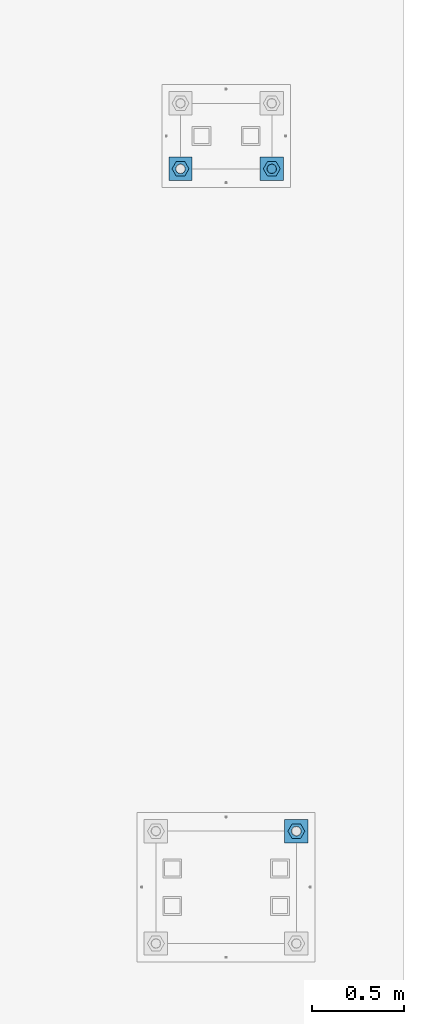
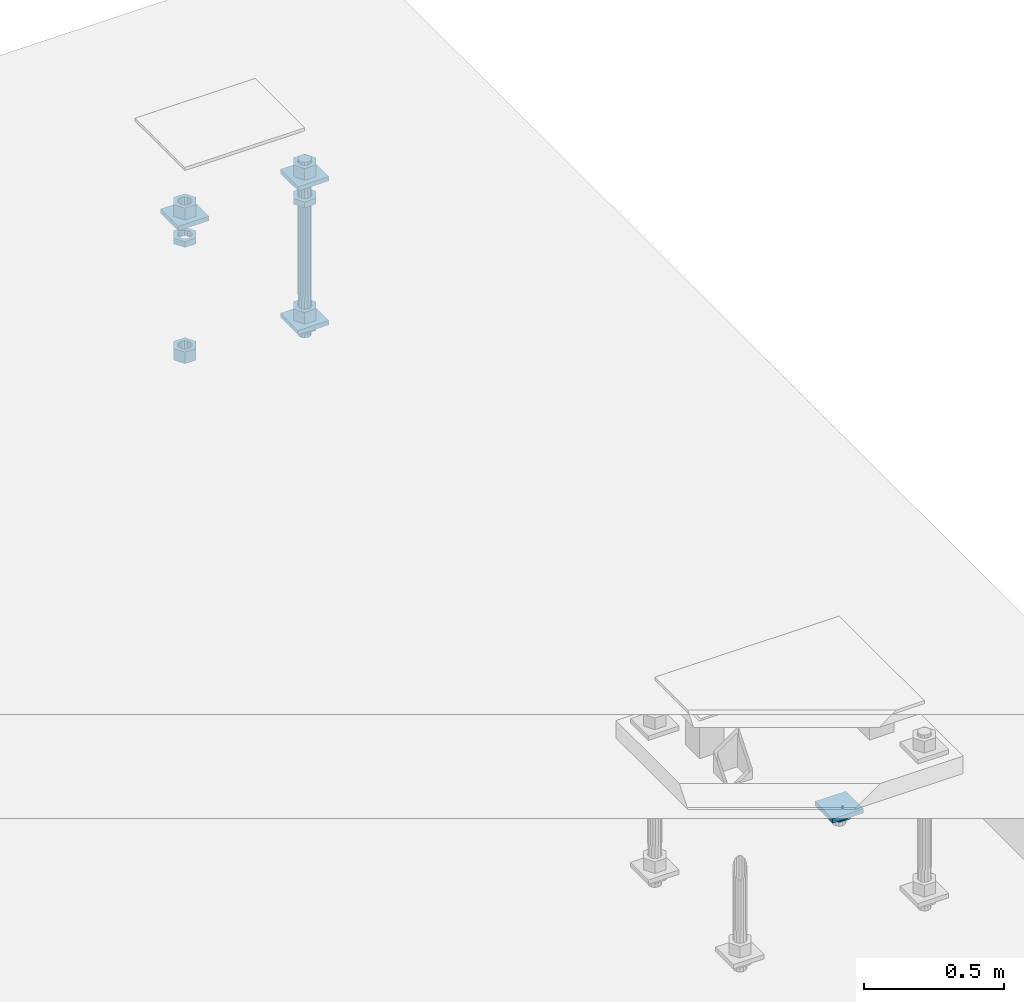
# One storey, part 2770 of 3843: 13 beams, 2 elements without a shape of their own.
"""IFC2X3 building model written with IfcOpenShell, lengths in millimetres."""

from ifc_helpers import new_model, si_unit, frame, origin_with_axes, place, context, subcontext, project, spatial, faceted_brep, material, type_object, element, aggregate, save


model = new_model("IFC2X3")

# Units and contexts
model_context = context("Model", 3, precision=1e-05, world=origin_with_axes())
body_context = subcontext(model_context, "Body", "Model", "MODEL_VIEW")
ifc_project = project(units=[si_unit("LENGTHUNIT", "METRE", prefix="MILLI"), si_unit("AREAUNIT", "SQUARE_METRE"), si_unit("VOLUMEUNIT", "CUBIC_METRE"), si_unit("MASSUNIT", "GRAM", prefix="KILO"), si_unit("TIMEUNIT", "SECOND"), si_unit("PLANEANGLEUNIT", "RADIAN"), si_unit("SOLIDANGLEUNIT", "STERADIAN"), si_unit("THERMODYNAMICTEMPERATUREUNIT", "DEGREE_CELSIUS"), si_unit("LUMINOUSINTENSITYUNIT", "LUMEN")], contexts=[model_context])

# Site, building, storey
site_placement = place(None, origin_with_axes())
site = spatial("IfcSite", under=ifc_project, at=site_placement, CompositionType="ELEMENT")
building_placement = place(site_placement, origin_with_axes())
building = spatial("IfcBuilding", under=site, at=building_placement, Name="Undefined", CompositionType="ELEMENT")
storey_placement = place(building_placement, origin_with_axes())
storey = spatial("IfcBuildingStorey", under=building, at=storey_placement, Name="Undefined", CompositionType="ELEMENT", Elevation=0.0)

# Assembly, beams
assembly_1_placement = place(storey_placement, origin_with_axes())
assembly_1 = element("IfcElementAssembly", 1, at=assembly_1_placement, inside=storey, Name="TEMPLATE", AssemblyPlace="NOTDEFINED", PredefinedType="RIGID_FRAME")
ifc_material_1 = material(Name="STEEL/A572-50")
beam_type_1 = type_object("IfcBeamType", PredefinedType="NOTDEFINED")
beam_1_placement = place(assembly_1_placement, frame((119094.25, 52590.6999984741, 29873.575), z_axis=(-1.0, 0.0, 0.0), x_axis=(0.0, -1.0, 0.0)))
beam_1 = element("IfcBeam", 2, at=beam_1_placement, type_object=beam_type_1, material=ifc_material_1, Name="WASHER_PLATE", context=body_context, shape_type="Brep", body=[
    faceted_brep([(0.0, 9.52500000000146, -63.5), (0.0, 9.52500000000146, 63.5), (127.0, 9.52500000000146, 63.5), (127.0, 9.52500000000146, -63.5), (0.0, -9.52500000000146, 63.5), (127.0, -9.52500000000146, 63.5), (0.0, -9.52500000000146, -63.5), (127.0, -9.52500000000146, -63.5)], [[[0, 1, 2, 3]], [[1, 4, 5, 2]], [[4, 6, 7, 5]], [[6, 0, 3, 7]], [[5, 7, 3, 2]], [[6, 4, 1, 0]]]),
])
beam_2_placement = place(assembly_1_placement, frame((118598.95, 52590.6999984741, 29873.575), z_axis=(-1.0, 0.0, 0.0), x_axis=(0.0, -1.0, 0.0)))
beam_2 = element("IfcBeam", 3, at=beam_2_placement, type_object=beam_type_1, material=ifc_material_1, Name="WASHER_PLATE", context=body_context, shape_type="Brep", body=[
    faceted_brep([(0.0, 9.52500000000146, -63.5), (0.0, 9.52500000000146, 63.5), (127.0, 9.52500000000146, 63.5), (127.0, 9.52500000000146, -63.5), (0.0, -9.52500000000146, 63.5), (127.0, -9.52500000000146, 63.5), (0.0, -9.52500000000146, -63.5), (127.0, -9.52500000000146, -63.5)], [[[0, 1, 2, 3]], [[1, 4, 5, 2]], [[4, 6, 7, 5]], [[6, 0, 3, 7]], [[5, 7, 3, 2]], [[6, 4, 1, 0]]]),
])
beam_3_placement = place(assembly_1_placement, frame((119094.25, 52590.6999984741, 29244.925), z_axis=(-1.0, 0.0, 0.0), x_axis=(0.0, -1.0, 0.0)))
beam_3 = element("IfcBeam", 4, at=beam_3_placement, type_object=beam_type_1, material=ifc_material_1, Name="WASHER_PLATE", context=body_context, shape_type="Brep", body=[
    faceted_brep([(0.0, 9.52500000000146, -63.5), (0.0, 9.52500000000146, 63.5), (127.0, 9.52500000000146, 63.5), (127.0, 9.52500000000146, -63.5), (0.0, -9.52500000000146, 63.5), (127.0, -9.52500000000146, 63.5), (0.0, -9.52500000000146, -63.5), (127.0, -9.52500000000146, -63.5)], [[[0, 1, 2, 3]], [[1, 4, 5, 2]], [[4, 6, 7, 5]], [[6, 0, 3, 7]], [[5, 7, 3, 2]], [[6, 4, 1, 0]]]),
])

# Assembly, beam
assembly_2_placement = place(storey_placement, origin_with_axes())
assembly_2 = element("IfcElementAssembly", 5, at=assembly_2_placement, inside=storey, Name="TEMPLATE", AssemblyPlace="NOTDEFINED", PredefinedType="RIGID_FRAME")
beam_4_placement = place(assembly_2_placement, frame((119227.6, 48869.6000015259, 29244.925), z_axis=(1.0, 0.0, 0.0), x_axis=(0.0, 1.0, 0.0)))
beam_4 = element("IfcBeam", 6, at=beam_4_placement, type_object=beam_type_1, material=ifc_material_1, Name="WASHER_PLATE", context=body_context, shape_type="Brep", body=[
    faceted_brep([(0.0, 9.52500000000146, -63.5), (0.0, 9.52500000000146, 63.5), (127.0, 9.52500000000146, 63.5), (127.0, 9.52500000000146, -63.5), (0.0, -9.52500000000146, 63.5), (127.0, -9.52500000000146, 63.5), (0.0, -9.52500000000146, -63.5), (127.0, -9.52500000000146, -63.5)], [[[0, 1, 2, 3]], [[1, 4, 5, 2]], [[4, 6, 7, 5]], [[6, 0, 3, 7]], [[5, 7, 3, 2]], [[6, 4, 1, 0]]]),
])

# Beam
ifc_material_2 = material(Name="STEEL/A36")
beam_type_2 = type_object("IfcBeamType", Name="2_HALF_NUT", PredefinedType="NOTDEFINED")
beam_5_placement = place(assembly_1_placement, frame((119094.25, 52527.1999984741, 29787.85), z_axis=(0.0, -1.0, 0.0), x_axis=(0.0, 0.0, -1.0)))
beam_5 = element("IfcBeam", 7, at=beam_5_placement, type_object=beam_type_2, material=ifc_material_2, Name="NUT", ObjectType="2_HALF_NUT", context=body_context, shape_type="Brep", body=[
    faceted_brep([(0.0, -46.0369987487793, 0.0), (0.0, -23.0184993743896, -39.869213104248), (25.4000000000015, -23.0184993743896, -39.869213104248), (25.4000000000015, -46.0369987487793, 0.0), (0.0, 23.0184993743896, -39.869213104248), (25.4000000000015, 23.0184993743896, -39.869213104248), (0.0, 46.0369987487793, 0.0), (25.4000000000015, 46.0369987487793, 0.0), (0.0, 23.0184993743896, 39.869213104248), (25.4000000000015, 23.0184993743896, 39.869213104248), (0.0, -23.0184993743896, 39.869213104248), (25.4000000000015, -23.0184993743896, 39.869213104248), (0.0, 0.0, 26.1940002441406), (0.0, 11.3650617044477, 23.5999013092805), (25.4000000000015, 11.3650617044477, 23.5999013092805), (25.4000000000015, 0.0, 26.1940002441406), (0.0, 20.4791109456419, 16.3316083006721), (25.4000000000015, 20.4791109456419, 16.3316083006721), (0.0, 25.5370200498292, 5.82867859874386), (25.4000000000015, 25.5370200498292, 5.82867859874386), (0.0, 25.5370200498292, -5.82867859874386), (25.4000000000015, 25.5370200498292, -5.82867859874386), (0.0, 20.4791109456419, -16.3316083006721), (25.4000000000015, 20.4791109456419, -16.3316083006721), (0.0, 11.3650617044477, -23.5999013092805), (25.4000000000015, 11.3650617044477, -23.5999013092805), (0.0, 0.0, -26.1940002441406), (25.4000000000015, 0.0, -26.1940002441406), (0.0, -11.3650617044477, -23.5999013092805), (25.4000000000015, -11.3650617044477, -23.5999013092805), (0.0, -20.4791109456419, -16.3316083006721), (25.4000000000015, -20.4791109456419, -16.3316083006721), (0.0, -25.5370200498292, -5.82867859874386), (25.4000000000015, -25.5370200498292, -5.82867859874386), (0.0, -25.5370200498292, 5.82867859874386), (25.4000000000015, -25.5370200498292, 5.82867859874386), (0.0, -20.4791109456419, 16.3316083006721), (25.4000000000015, -20.4791109456419, 16.3316083006721), (0.0, -11.3650617044477, 23.5999013092805), (25.4000000000015, -11.3650617044477, 23.5999013092805)], [[[0, 1, 2, 3]], [[1, 4, 5, 2]], [[4, 6, 7, 5]], [[6, 8, 9, 7]], [[8, 10, 11, 9]], [[10, 0, 3, 11]], [[12, 13, 14, 15]], [[13, 16, 17, 14]], [[16, 18, 19, 17]], [[18, 20, 21, 19]], [[20, 22, 23, 21]], [[22, 24, 25, 23]], [[24, 26, 27, 25]], [[26, 28, 29, 27]], [[28, 30, 31, 29]], [[30, 32, 33, 31]], [[32, 34, 35, 33]], [[34, 36, 37, 35]], [[36, 38, 39, 37]], [[38, 12, 15, 39]], [[5, 7, 9, 11, 3, 2], [17, 19, 21, 23, 25, 27, 29, 31, 33, 35, 37, 39, 15, 14]], [[10, 8, 6, 4, 1, 0], [38, 36, 34, 32, 30, 28, 26, 24, 22, 20, 18, 16, 13, 12]]]),
])

beam_6_placement = place(assembly_1_placement, frame((119094.25, 52527.1999984741, 29235.4), z_axis=(0.0, -1.0, 0.0), x_axis=(0.0, 0.0, -1.0)))
beam_6 = element("IfcBeam", 8, at=beam_6_placement, type_object=beam_type_2, material=ifc_material_2, Name="NUT", ObjectType="2_HALF_NUT", context=body_context, shape_type="Brep", body=[
    faceted_brep([(0.0, -46.0369987487793, 0.0), (0.0, -23.0184993743896, -39.869213104248), (25.4000000000015, -23.0184993743896, -39.869213104248), (25.4000000000015, -46.0369987487793, 0.0), (0.0, 23.0184993743896, -39.869213104248), (25.4000000000015, 23.0184993743896, -39.869213104248), (0.0, 46.0369987487793, 0.0), (25.4000000000015, 46.0369987487793, 0.0), (0.0, 23.0184993743896, 39.869213104248), (25.4000000000015, 23.0184993743896, 39.869213104248), (0.0, -23.0184993743896, 39.869213104248), (25.4000000000015, -23.0184993743896, 39.869213104248), (0.0, 0.0, 26.1940002441406), (0.0, 11.3650617044477, 23.5999013092805), (25.4000000000015, 11.3650617044477, 23.5999013092805), (25.4000000000015, 0.0, 26.1940002441406), (0.0, 20.4791109456419, 16.3316083006721), (25.4000000000015, 20.4791109456419, 16.3316083006721), (0.0, 25.5370200498292, 5.82867859874386), (25.4000000000015, 25.5370200498292, 5.82867859874386), (0.0, 25.5370200498292, -5.82867859874386), (25.4000000000015, 25.5370200498292, -5.82867859874386), (0.0, 20.4791109456419, -16.3316083006721), (25.4000000000015, 20.4791109456419, -16.3316083006721), (0.0, 11.3650617044477, -23.5999013092805), (25.4000000000015, 11.3650617044477, -23.5999013092805), (0.0, 0.0, -26.1940002441406), (25.4000000000015, 0.0, -26.1940002441406), (0.0, -11.3650617044477, -23.5999013092805), (25.4000000000015, -11.3650617044477, -23.5999013092805), (0.0, -20.4791109456419, -16.3316083006721), (25.4000000000015, -20.4791109456419, -16.3316083006721), (0.0, -25.5370200498292, -5.82867859874386), (25.4000000000015, -25.5370200498292, -5.82867859874386), (0.0, -25.5370200498292, 5.82867859874386), (25.4000000000015, -25.5370200498292, 5.82867859874386), (0.0, -20.4791109456419, 16.3316083006721), (25.4000000000015, -20.4791109456419, 16.3316083006721), (0.0, -11.3650617044477, 23.5999013092805), (25.4000000000015, -11.3650617044477, 23.5999013092805)], [[[0, 1, 2, 3]], [[1, 4, 5, 2]], [[4, 6, 7, 5]], [[6, 8, 9, 7]], [[8, 10, 11, 9]], [[10, 0, 3, 11]], [[12, 13, 14, 15]], [[13, 16, 17, 14]], [[16, 18, 19, 17]], [[18, 20, 21, 19]], [[20, 22, 23, 21]], [[22, 24, 25, 23]], [[24, 26, 27, 25]], [[26, 28, 29, 27]], [[28, 30, 31, 29]], [[30, 32, 33, 31]], [[32, 34, 35, 33]], [[34, 36, 37, 35]], [[36, 38, 39, 37]], [[38, 12, 15, 39]], [[5, 7, 9, 11, 3, 2], [17, 19, 21, 23, 25, 27, 29, 31, 33, 35, 37, 39, 15, 14]], [[10, 8, 6, 4, 1, 0], [38, 36, 34, 32, 30, 28, 26, 24, 22, 20, 18, 16, 13, 12]]]),
])

beam_7_placement = place(assembly_1_placement, frame((118598.95, 52527.1999984741, 29787.85), z_axis=(0.0, -1.0, 0.0), x_axis=(0.0, 0.0, -1.0)))
beam_7 = element("IfcBeam", 9, at=beam_7_placement, type_object=beam_type_2, material=ifc_material_2, Name="NUT", ObjectType="2_HALF_NUT", context=body_context, shape_type="Brep", body=[
    faceted_brep([(0.0, -46.0369987487793, 0.0), (0.0, -23.0184993743896, -39.869213104248), (25.4000000000015, -23.0184993743896, -39.869213104248), (25.4000000000015, -46.0369987487793, 0.0), (0.0, 23.0184993743896, -39.869213104248), (25.4000000000015, 23.0184993743896, -39.869213104248), (0.0, 46.0369987487793, 0.0), (25.4000000000015, 46.0369987487793, 0.0), (0.0, 23.0184993743896, 39.869213104248), (25.4000000000015, 23.0184993743896, 39.869213104248), (0.0, -23.0184993743896, 39.869213104248), (25.4000000000015, -23.0184993743896, 39.869213104248), (0.0, 0.0, 26.1940002441406), (0.0, 11.3650617044477, 23.5999013092805), (25.4000000000015, 11.3650617044477, 23.5999013092805), (25.4000000000015, 0.0, 26.1940002441406), (0.0, 20.4791109456419, 16.3316083006721), (25.4000000000015, 20.4791109456419, 16.3316083006721), (0.0, 25.5370200498292, 5.82867859874386), (25.4000000000015, 25.5370200498292, 5.82867859874386), (0.0, 25.5370200498292, -5.82867859874386), (25.4000000000015, 25.5370200498292, -5.82867859874386), (0.0, 20.4791109456419, -16.3316083006721), (25.4000000000015, 20.4791109456419, -16.3316083006721), (0.0, 11.3650617044477, -23.5999013092805), (25.4000000000015, 11.3650617044477, -23.5999013092805), (0.0, 0.0, -26.1940002441406), (25.4000000000015, 0.0, -26.1940002441406), (0.0, -11.3650617044477, -23.5999013092805), (25.4000000000015, -11.3650617044477, -23.5999013092805), (0.0, -20.4791109456419, -16.3316083006721), (25.4000000000015, -20.4791109456419, -16.3316083006721), (0.0, -25.5370200498292, -5.82867859874386), (25.4000000000015, -25.5370200498292, -5.82867859874386), (0.0, -25.5370200498292, 5.82867859874386), (25.4000000000015, -25.5370200498292, 5.82867859874386), (0.0, -20.4791109456419, 16.3316083006721), (25.4000000000015, -20.4791109456419, 16.3316083006721), (0.0, -11.3650617044477, 23.5999013092805), (25.4000000000015, -11.3650617044477, 23.5999013092805)], [[[0, 1, 2, 3]], [[1, 4, 5, 2]], [[4, 6, 7, 5]], [[6, 8, 9, 7]], [[8, 10, 11, 9]], [[10, 0, 3, 11]], [[12, 13, 14, 15]], [[13, 16, 17, 14]], [[16, 18, 19, 17]], [[18, 20, 21, 19]], [[20, 22, 23, 21]], [[22, 24, 25, 23]], [[24, 26, 27, 25]], [[26, 28, 29, 27]], [[28, 30, 31, 29]], [[30, 32, 33, 31]], [[32, 34, 35, 33]], [[34, 36, 37, 35]], [[36, 38, 39, 37]], [[38, 12, 15, 39]], [[5, 7, 9, 11, 3, 2], [17, 19, 21, 23, 25, 27, 29, 31, 33, 35, 37, 39, 15, 14]], [[10, 8, 6, 4, 1, 0], [38, 36, 34, 32, 30, 28, 26, 24, 22, 20, 18, 16, 13, 12]]]),
])

beam_8_placement = place(assembly_2_placement, frame((119227.6, 48933.1000015259, 29235.4), z_axis=(0.0, 1.0, 0.0), x_axis=(0.0, 0.0, -1.0)))
beam_8 = element("IfcBeam", 10, at=beam_8_placement, type_object=beam_type_2, material=ifc_material_2, Name="NUT", ObjectType="2_HALF_NUT", context=body_context, shape_type="Brep", body=[
    faceted_brep([(0.0, -46.0369987487793, 0.0), (0.0, -23.0184993743896, -39.869213104248), (25.4000000000015, -23.0184993743896, -39.869213104248), (25.4000000000015, -46.0369987487793, 0.0), (0.0, 23.0184993743896, -39.869213104248), (25.4000000000015, 23.0184993743896, -39.869213104248), (0.0, 46.0369987487793, 0.0), (25.4000000000015, 46.0369987487793, 0.0), (0.0, 23.0184993743896, 39.869213104248), (25.4000000000015, 23.0184993743896, 39.869213104248), (0.0, -23.0184993743896, 39.869213104248), (25.4000000000015, -23.0184993743896, 39.869213104248), (0.0, 0.0, 26.1940002441406), (0.0, 11.3650617044477, 23.5999013092805), (25.4000000000015, 11.3650617044477, 23.5999013092805), (25.4000000000015, 0.0, 26.1940002441406), (0.0, 20.4791109456419, 16.3316083006721), (25.4000000000015, 20.4791109456419, 16.3316083006721), (0.0, 25.5370200498292, 5.82867859874386), (25.4000000000015, 25.5370200498292, 5.82867859874386), (0.0, 25.5370200498292, -5.82867859874386), (25.4000000000015, 25.5370200498292, -5.82867859874386), (0.0, 20.4791109456419, -16.3316083006721), (25.4000000000015, 20.4791109456419, -16.3316083006721), (0.0, 11.3650617044477, -23.5999013092805), (25.4000000000015, 11.3650617044477, -23.5999013092805), (0.0, 0.0, -26.1940002441406), (25.4000000000015, 0.0, -26.1940002441406), (0.0, -11.3650617044477, -23.5999013092805), (25.4000000000015, -11.3650617044477, -23.5999013092805), (0.0, -20.4791109456419, -16.3316083006721), (25.4000000000015, -20.4791109456419, -16.3316083006721), (0.0, -25.5370200498292, -5.82867859874386), (25.4000000000015, -25.5370200498292, -5.82867859874386), (0.0, -25.5370200498292, 5.82867859874386), (25.4000000000015, -25.5370200498292, 5.82867859874386), (0.0, -20.4791109456419, 16.3316083006721), (25.4000000000015, -20.4791109456419, 16.3316083006721), (0.0, -11.3650617044477, 23.5999013092805), (25.4000000000015, -11.3650617044477, 23.5999013092805)], [[[0, 1, 2, 3]], [[1, 4, 5, 2]], [[4, 6, 7, 5]], [[6, 8, 9, 7]], [[8, 10, 11, 9]], [[10, 0, 3, 11]], [[12, 13, 14, 15]], [[13, 16, 17, 14]], [[16, 18, 19, 17]], [[18, 20, 21, 19]], [[20, 22, 23, 21]], [[22, 24, 25, 23]], [[24, 26, 27, 25]], [[26, 28, 29, 27]], [[28, 30, 31, 29]], [[30, 32, 33, 31]], [[32, 34, 35, 33]], [[34, 36, 37, 35]], [[36, 38, 39, 37]], [[38, 12, 15, 39]], [[5, 7, 9, 11, 3, 2], [17, 19, 21, 23, 25, 27, 29, 31, 33, 35, 37, 39, 15, 14]], [[10, 8, 6, 4, 1, 0], [38, 36, 34, 32, 30, 28, 26, 24, 22, 20, 18, 16, 13, 12]]]),
])

aggregate(assembly_2, [beam_8, beam_4])

beam_type_3 = type_object("IfcBeamType", Name="2_HEAVY_HEX_NUT", PredefinedType="NOTDEFINED")
beam_9_placement = place(assembly_1_placement, frame((119094.25, 52527.1999984741, 29933.9), z_axis=(0.0, -1.0, 0.0), x_axis=(0.0, 0.0, -1.0)))
beam_9 = element("IfcBeam", 11, at=beam_9_placement, type_object=beam_type_3, material=ifc_material_2, Name="NUT", ObjectType="2_HEAVY_HEX_NUT", context=body_context, shape_type="Brep", body=[
    faceted_brep([(0.0, -46.0369987487793, 0.0), (0.0, -23.0184993743896, -39.869213104248), (50.7999999999993, -23.0184993743896, -39.869213104248), (50.7999999999993, -46.0369987487793, 0.0), (0.0, 23.0184993743896, -39.869213104248), (50.7999999999993, 23.0184993743896, -39.869213104248), (0.0, 46.0369987487793, 0.0), (50.7999999999993, 46.0369987487793, 0.0), (0.0, 23.0184993743896, 39.869213104248), (50.7999999999993, 23.0184993743896, 39.869213104248), (0.0, -23.0184993743896, 39.869213104248), (50.7999999999993, -23.0184993743896, 39.869213104248), (0.0, 0.0, 26.1940002441406), (0.0, 11.3650617044477, 23.5999013092805), (50.7999999999993, 11.3650617044477, 23.5999013092805), (50.7999999999993, 0.0, 26.1940002441406), (0.0, 20.4791109456419, 16.3316083006721), (50.7999999999993, 20.4791109456419, 16.3316083006721), (0.0, 25.5370200498292, 5.82867859874386), (50.7999999999993, 25.5370200498292, 5.82867859874386), (0.0, 25.5370200498292, -5.82867859874386), (50.7999999999993, 25.5370200498292, -5.82867859874386), (0.0, 20.4791109456419, -16.3316083006721), (50.7999999999993, 20.4791109456419, -16.3316083006721), (0.0, 11.3650617044477, -23.5999013092805), (50.7999999999993, 11.3650617044477, -23.5999013092805), (0.0, 0.0, -26.1940002441406), (50.7999999999993, 0.0, -26.1940002441406), (0.0, -11.3650617044477, -23.5999013092805), (50.7999999999993, -11.3650617044477, -23.5999013092805), (0.0, -20.4791109456419, -16.3316083006721), (50.7999999999993, -20.4791109456419, -16.3316083006721), (0.0, -25.5370200498292, -5.82867859874386), (50.7999999999993, -25.5370200498292, -5.82867859874386), (0.0, -25.5370200498292, 5.82867859874386), (50.7999999999993, -25.5370200498292, 5.82867859874386), (0.0, -20.4791109456419, 16.3316083006721), (50.7999999999993, -20.4791109456419, 16.3316083006721), (0.0, -11.3650617044477, 23.5999013092805), (50.7999999999993, -11.3650617044477, 23.5999013092805)], [[[0, 1, 2, 3]], [[1, 4, 5, 2]], [[4, 6, 7, 5]], [[6, 8, 9, 7]], [[8, 10, 11, 9]], [[10, 0, 3, 11]], [[12, 13, 14, 15]], [[13, 16, 17, 14]], [[16, 18, 19, 17]], [[18, 20, 21, 19]], [[20, 22, 23, 21]], [[22, 24, 25, 23]], [[24, 26, 27, 25]], [[26, 28, 29, 27]], [[28, 30, 31, 29]], [[30, 32, 33, 31]], [[32, 34, 35, 33]], [[34, 36, 37, 35]], [[36, 38, 39, 37]], [[38, 12, 15, 39]], [[5, 7, 9, 11, 3, 2], [17, 19, 21, 23, 25, 27, 29, 31, 33, 35, 37, 39, 15, 14]], [[10, 8, 6, 4, 1, 0], [38, 36, 34, 32, 30, 28, 26, 24, 22, 20, 18, 16, 13, 12]]]),
])

beam_10_placement = place(assembly_1_placement, frame((119094.25, 52527.1999984741, 29305.25), z_axis=(0.0, -1.0, 0.0), x_axis=(0.0, 0.0, -1.0)))
beam_10 = element("IfcBeam", 12, at=beam_10_placement, type_object=beam_type_3, material=ifc_material_2, Name="NUT", ObjectType="2_HEAVY_HEX_NUT", context=body_context, shape_type="Brep", body=[
    faceted_brep([(0.0, -46.0369987487793, 0.0), (0.0, -23.0184993743896, -39.869213104248), (50.7999999999993, -23.0184993743896, -39.869213104248), (50.7999999999993, -46.0369987487793, 0.0), (0.0, 23.0184993743896, -39.869213104248), (50.7999999999993, 23.0184993743896, -39.869213104248), (0.0, 46.0369987487793, 0.0), (50.7999999999993, 46.0369987487793, 0.0), (0.0, 23.0184993743896, 39.869213104248), (50.7999999999993, 23.0184993743896, 39.869213104248), (0.0, -23.0184993743896, 39.869213104248), (50.7999999999993, -23.0184993743896, 39.869213104248), (0.0, 0.0, 26.1940002441406), (0.0, 11.3650617044477, 23.5999013092805), (50.7999999999993, 11.3650617044477, 23.5999013092805), (50.7999999999993, 0.0, 26.1940002441406), (0.0, 20.4791109456419, 16.3316083006721), (50.7999999999993, 20.4791109456419, 16.3316083006721), (0.0, 25.5370200498292, 5.82867859874386), (50.7999999999993, 25.5370200498292, 5.82867859874386), (0.0, 25.5370200498292, -5.82867859874386), (50.7999999999993, 25.5370200498292, -5.82867859874386), (0.0, 20.4791109456419, -16.3316083006721), (50.7999999999993, 20.4791109456419, -16.3316083006721), (0.0, 11.3650617044477, -23.5999013092805), (50.7999999999993, 11.3650617044477, -23.5999013092805), (0.0, 0.0, -26.1940002441406), (50.7999999999993, 0.0, -26.1940002441406), (0.0, -11.3650617044477, -23.5999013092805), (50.7999999999993, -11.3650617044477, -23.5999013092805), (0.0, -20.4791109456419, -16.3316083006721), (50.7999999999993, -20.4791109456419, -16.3316083006721), (0.0, -25.5370200498292, -5.82867859874386), (50.7999999999993, -25.5370200498292, -5.82867859874386), (0.0, -25.5370200498292, 5.82867859874386), (50.7999999999993, -25.5370200498292, 5.82867859874386), (0.0, -20.4791109456419, 16.3316083006721), (50.7999999999993, -20.4791109456419, 16.3316083006721), (0.0, -11.3650617044477, 23.5999013092805), (50.7999999999993, -11.3650617044477, 23.5999013092805)], [[[0, 1, 2, 3]], [[1, 4, 5, 2]], [[4, 6, 7, 5]], [[6, 8, 9, 7]], [[8, 10, 11, 9]], [[10, 0, 3, 11]], [[12, 13, 14, 15]], [[13, 16, 17, 14]], [[16, 18, 19, 17]], [[18, 20, 21, 19]], [[20, 22, 23, 21]], [[22, 24, 25, 23]], [[24, 26, 27, 25]], [[26, 28, 29, 27]], [[28, 30, 31, 29]], [[30, 32, 33, 31]], [[32, 34, 35, 33]], [[34, 36, 37, 35]], [[36, 38, 39, 37]], [[38, 12, 15, 39]], [[5, 7, 9, 11, 3, 2], [17, 19, 21, 23, 25, 27, 29, 31, 33, 35, 37, 39, 15, 14]], [[10, 8, 6, 4, 1, 0], [38, 36, 34, 32, 30, 28, 26, 24, 22, 20, 18, 16, 13, 12]]]),
])

beam_11_placement = place(assembly_1_placement, frame((118598.95, 52527.1999984741, 29933.9), z_axis=(0.0, -1.0, 0.0), x_axis=(0.0, 0.0, -1.0)))
beam_11 = element("IfcBeam", 13, at=beam_11_placement, type_object=beam_type_3, material=ifc_material_2, Name="NUT", ObjectType="2_HEAVY_HEX_NUT", context=body_context, shape_type="Brep", body=[
    faceted_brep([(0.0, -46.0369987487793, 0.0), (0.0, -23.0184993743896, -39.869213104248), (50.7999999999993, -23.0184993743896, -39.869213104248), (50.7999999999993, -46.0369987487793, 0.0), (0.0, 23.0184993743896, -39.869213104248), (50.7999999999993, 23.0184993743896, -39.869213104248), (0.0, 46.0369987487793, 0.0), (50.7999999999993, 46.0369987487793, 0.0), (0.0, 23.0184993743896, 39.869213104248), (50.7999999999993, 23.0184993743896, 39.869213104248), (0.0, -23.0184993743896, 39.869213104248), (50.7999999999993, -23.0184993743896, 39.869213104248), (0.0, 0.0, 26.1940002441406), (0.0, 11.3650617044477, 23.5999013092805), (50.7999999999993, 11.3650617044477, 23.5999013092805), (50.7999999999993, 0.0, 26.1940002441406), (0.0, 20.4791109456419, 16.3316083006721), (50.7999999999993, 20.4791109456419, 16.3316083006721), (0.0, 25.5370200498292, 5.82867859874386), (50.7999999999993, 25.5370200498292, 5.82867859874386), (0.0, 25.5370200498292, -5.82867859874386), (50.7999999999993, 25.5370200498292, -5.82867859874386), (0.0, 20.4791109456419, -16.3316083006721), (50.7999999999993, 20.4791109456419, -16.3316083006721), (0.0, 11.3650617044477, -23.5999013092805), (50.7999999999993, 11.3650617044477, -23.5999013092805), (0.0, 0.0, -26.1940002441406), (50.7999999999993, 0.0, -26.1940002441406), (0.0, -11.3650617044477, -23.5999013092805), (50.7999999999993, -11.3650617044477, -23.5999013092805), (0.0, -20.4791109456419, -16.3316083006721), (50.7999999999993, -20.4791109456419, -16.3316083006721), (0.0, -25.5370200498292, -5.82867859874386), (50.7999999999993, -25.5370200498292, -5.82867859874386), (0.0, -25.5370200498292, 5.82867859874386), (50.7999999999993, -25.5370200498292, 5.82867859874386), (0.0, -20.4791109456419, 16.3316083006721), (50.7999999999993, -20.4791109456419, 16.3316083006721), (0.0, -11.3650617044477, 23.5999013092805), (50.7999999999993, -11.3650617044477, 23.5999013092805)], [[[0, 1, 2, 3]], [[1, 4, 5, 2]], [[4, 6, 7, 5]], [[6, 8, 9, 7]], [[8, 10, 11, 9]], [[10, 0, 3, 11]], [[12, 13, 14, 15]], [[13, 16, 17, 14]], [[16, 18, 19, 17]], [[18, 20, 21, 19]], [[20, 22, 23, 21]], [[22, 24, 25, 23]], [[24, 26, 27, 25]], [[26, 28, 29, 27]], [[28, 30, 31, 29]], [[30, 32, 33, 31]], [[32, 34, 35, 33]], [[34, 36, 37, 35]], [[36, 38, 39, 37]], [[38, 12, 15, 39]], [[5, 7, 9, 11, 3, 2], [17, 19, 21, 23, 25, 27, 29, 31, 33, 35, 37, 39, 15, 14]], [[10, 8, 6, 4, 1, 0], [38, 36, 34, 32, 30, 28, 26, 24, 22, 20, 18, 16, 13, 12]]]),
])

beam_12_placement = place(assembly_1_placement, frame((118598.95, 52527.1999984741, 29305.25), z_axis=(0.0, -1.0, 0.0), x_axis=(0.0, 0.0, -1.0)))
beam_12 = element("IfcBeam", 14, at=beam_12_placement, type_object=beam_type_3, material=ifc_material_2, Name="NUT", ObjectType="2_HEAVY_HEX_NUT", context=body_context, shape_type="Brep", body=[
    faceted_brep([(0.0, -46.0369987487793, 0.0), (0.0, -23.0184993743896, -39.869213104248), (50.7999999999993, -23.0184993743896, -39.869213104248), (50.7999999999993, -46.0369987487793, 0.0), (0.0, 23.0184993743896, -39.869213104248), (50.7999999999993, 23.0184993743896, -39.869213104248), (0.0, 46.0369987487793, 0.0), (50.7999999999993, 46.0369987487793, 0.0), (0.0, 23.0184993743896, 39.869213104248), (50.7999999999993, 23.0184993743896, 39.869213104248), (0.0, -23.0184993743896, 39.869213104248), (50.7999999999993, -23.0184993743896, 39.869213104248), (0.0, 0.0, 26.1940002441406), (0.0, 11.3650617044477, 23.5999013092805), (50.7999999999993, 11.3650617044477, 23.5999013092805), (50.7999999999993, 0.0, 26.1940002441406), (0.0, 20.4791109456419, 16.3316083006721), (50.7999999999993, 20.4791109456419, 16.3316083006721), (0.0, 25.5370200498292, 5.82867859874386), (50.7999999999993, 25.5370200498292, 5.82867859874386), (0.0, 25.5370200498292, -5.82867859874386), (50.7999999999993, 25.5370200498292, -5.82867859874386), (0.0, 20.4791109456419, -16.3316083006721), (50.7999999999993, 20.4791109456419, -16.3316083006721), (0.0, 11.3650617044477, -23.5999013092805), (50.7999999999993, 11.3650617044477, -23.5999013092805), (0.0, 0.0, -26.1940002441406), (50.7999999999993, 0.0, -26.1940002441406), (0.0, -11.3650617044477, -23.5999013092805), (50.7999999999993, -11.3650617044477, -23.5999013092805), (0.0, -20.4791109456419, -16.3316083006721), (50.7999999999993, -20.4791109456419, -16.3316083006721), (0.0, -25.5370200498292, -5.82867859874386), (50.7999999999993, -25.5370200498292, -5.82867859874386), (0.0, -25.5370200498292, 5.82867859874386), (50.7999999999993, -25.5370200498292, 5.82867859874386), (0.0, -20.4791109456419, 16.3316083006721), (50.7999999999993, -20.4791109456419, 16.3316083006721), (0.0, -11.3650617044477, 23.5999013092805), (50.7999999999993, -11.3650617044477, 23.5999013092805)], [[[0, 1, 2, 3]], [[1, 4, 5, 2]], [[4, 6, 7, 5]], [[6, 8, 9, 7]], [[8, 10, 11, 9]], [[10, 0, 3, 11]], [[12, 13, 14, 15]], [[13, 16, 17, 14]], [[16, 18, 19, 17]], [[18, 20, 21, 19]], [[20, 22, 23, 21]], [[22, 24, 25, 23]], [[24, 26, 27, 25]], [[26, 28, 29, 27]], [[28, 30, 31, 29]], [[30, 32, 33, 31]], [[32, 34, 35, 33]], [[34, 36, 37, 35]], [[36, 38, 39, 37]], [[38, 12, 15, 39]], [[5, 7, 9, 11, 3, 2], [17, 19, 21, 23, 25, 27, 29, 31, 33, 35, 37, 39, 15, 14]], [[10, 8, 6, 4, 1, 0], [38, 36, 34, 32, 30, 28, 26, 24, 22, 20, 18, 16, 13, 12]]]),
])

ifc_material_3 = material()
beam_type_4 = type_object("IfcBeamType", PredefinedType="NOTDEFINED")
beam_13_placement = place(assembly_1_placement, frame((119094.25, 52527.1999984741, 29762.45), z_axis=(0.0, -1.0, 0.0), x_axis=(0.0, 0.0, -1.0)))
beam_13 = element("IfcBeam", 15, at=beam_13_placement, type_object=beam_type_4, material=ifc_material_3, Name="ANCHOR_ROD", context=body_context, shape_type="Brep", body=[
    faceted_brep([(-184.150000000001, -21.217622392709, 12.25), (-184.150000000001, -12.2499999999854, 21.2176223927163), (-184.150000000001, 1.45519152283669e-11, 24.5), (-184.150000000001, 12.2500000000146, 21.2176223927163), (-184.150000000001, 21.2176223927381, 12.25), (-184.150000000001, 24.5000000000146, 0.0), (-184.150000000001, 21.2176223927381, -12.25), (-184.150000000001, 12.2500000000146, -21.2176223927163), (-184.150000000001, 1.45519152283669e-11, -24.5), (-184.150000000001, -12.2499999999854, -21.2176223927163), (-184.150000000001, -21.217622392709, -12.25), (-184.150000000001, -24.4999999999854, 0.0), (0.0, 24.5000000000146, 0.0), (0.0, 21.2176223927381, -12.25), (0.0, 12.2500000000146, -21.2176223927163), (0.0, 1.45519152283669e-11, -24.5), (0.0, -12.2499999999854, -21.2176223927163), (0.0, -21.217622392709, -12.25), (0.0, -24.4999999999854, 0.0), (0.0, -21.217622392709, 12.25), (0.0, -12.2499999999854, 21.2176223927163), (0.0, 1.45519152283669e-11, 24.5), (0.0, 12.2500000000146, 21.2176223927163), (0.0, 21.2176223927381, 12.25), (0.0, -23.4665401257807, 9.72015918207035), (0.0, -17.9605122421344, 17.9605122421417), (0.0, -9.72015918207762, 23.466540125788), (0.0, 0.0, 25.4000000000015), (0.0, 9.72015918207762, 23.466540125788), (0.0, 17.9605122421344, 17.9605122421417), (0.0, 23.4665401257807, 9.72015918207035), (0.0, 25.3999996185303, 0.0), (0.0, 23.4665401257807, -9.72015918207035), (0.0, 17.9605122421344, -17.9605122421417), (0.0, 9.72015918207762, -23.466540125788), (0.0, 0.0, -25.4000000000015), (0.0, -9.72015918207762, -23.466540125788), (0.0, -17.9605122421344, -17.9605122421417), (0.0, -23.4665401257807, -9.72015918207035), (0.0, -25.3999996185303, 0.0), (406.399999999998, -25.3999999999942, 0.0), (406.399999999998, -23.4665401257807, 9.72015918207035), (406.399999999998, -17.9605122421344, 17.9605122421417), (406.399999999998, -9.72015918207762, 23.466540125788), (406.399999999998, 0.0, 25.4000000000015), (406.399999999998, 9.72015918207762, 23.466540125788), (406.399999999998, 17.9605122421344, 17.9605122421417), (406.399999999998, 23.4665401257807, 9.72015918207035), (406.399999999998, 25.3999999999942, 0.0), (406.399999999998, 23.4665401257807, -9.72015918207035), (406.399999999998, 17.9605122421344, -17.9605122421417), (406.399999999998, 9.72015918207762, -23.466540125788), (406.399999999998, 0.0, -25.4000000000015), (406.399999999998, -9.72015918207762, -23.466540125788), (406.399999999998, -17.9605122421344, -17.9605122421417), (406.399999999998, -23.4665401257807, -9.72015918207035), (406.399999999998, -12.2499999999854, 21.2176223927163), (406.399999999998, 1.45519152283669e-11, 24.5), (406.399999999998, 12.2500000000146, 21.2176223927163), (406.399999999998, 21.2176223927381, 12.25), (406.399999999998, 24.5000000000146, 0.0), (406.399999999998, 21.2176223927381, -12.25), (406.399999999998, 12.2500000000146, -21.2176223927163), (406.399999999998, 1.45519152283669e-11, -24.5), (406.399999999998, -12.2499999999854, -21.2176223927163), (406.399999999998, -21.217622392709, -12.25), (406.399999999998, -24.4999999999854, 0.0), (406.399999999998, -21.217622392709, 12.25), (584.200000000001, -12.2499999999854, -21.2176223927163), (584.200000000001, 1.45519152283669e-11, -24.5), (584.200000000001, 12.2500000000146, -21.2176223927163), (584.200000000001, 21.2176223927381, -12.25), (584.200000000001, 24.5000000000146, 0.0), (584.200000000001, 21.2176223927381, 12.25), (584.200000000001, 12.2500000000146, 21.2176223927163), (584.200000000001, 1.45519152283669e-11, 24.5), (584.200000000001, -12.2499999999854, 21.2176223927163), (584.200000000001, -21.217622392709, 12.25), (584.200000000001, -24.4999999999854, 0.0), (584.200000000001, -21.217622392709, -12.25)], [[[0, 1, 2, 3, 4, 5, 6, 7, 8, 9, 10, 11]], [[6, 5, 12, 13]], [[7, 6, 13, 14]], [[8, 7, 14, 15]], [[9, 8, 15, 16]], [[10, 9, 16, 17]], [[11, 10, 17, 18]], [[0, 11, 18, 19]], [[1, 0, 19, 20]], [[2, 1, 20, 21]], [[3, 2, 21, 22]], [[4, 3, 22, 23]], [[5, 4, 23, 12]], [[24, 25, 26, 27, 28, 29, 30, 31, 32, 33, 34, 35, 36, 37, 38, 39], [22, 21, 20, 19, 18, 17, 16, 15, 14, 13, 12, 23]], [[24, 39, 40, 41]], [[25, 24, 41, 42]], [[26, 25, 42, 43]], [[27, 26, 43, 44]], [[28, 27, 44, 45]], [[29, 28, 45, 46]], [[30, 29, 46, 47]], [[31, 30, 47, 48]], [[32, 31, 48, 49]], [[33, 32, 49, 50]], [[34, 33, 50, 51]], [[35, 34, 51, 52]], [[36, 35, 52, 53]], [[37, 36, 53, 54]], [[38, 37, 54, 55]], [[39, 38, 55, 40]], [[54, 53, 52, 51, 50, 49, 48, 47, 46, 45, 44, 43, 42, 41, 40, 55], [56, 57, 58, 59, 60, 61, 62, 63, 64, 65, 66, 67]], [[68, 69, 70, 71, 72, 73, 74, 75, 76, 77, 78, 79]], [[76, 75, 57, 56]], [[77, 76, 56, 67]], [[78, 77, 67, 66]], [[79, 78, 66, 65]], [[68, 79, 65, 64]], [[69, 68, 64, 63]], [[70, 69, 63, 62]], [[71, 70, 62, 61]], [[72, 71, 61, 60]], [[73, 72, 60, 59]], [[74, 73, 59, 58]], [[75, 74, 58, 57]]]),
])

aggregate(assembly_1, [beam_1, beam_2, beam_5, beam_9, beam_10, beam_6, beam_3, beam_13, beam_7, beam_11, beam_12])

save(model, "model.ifc")
